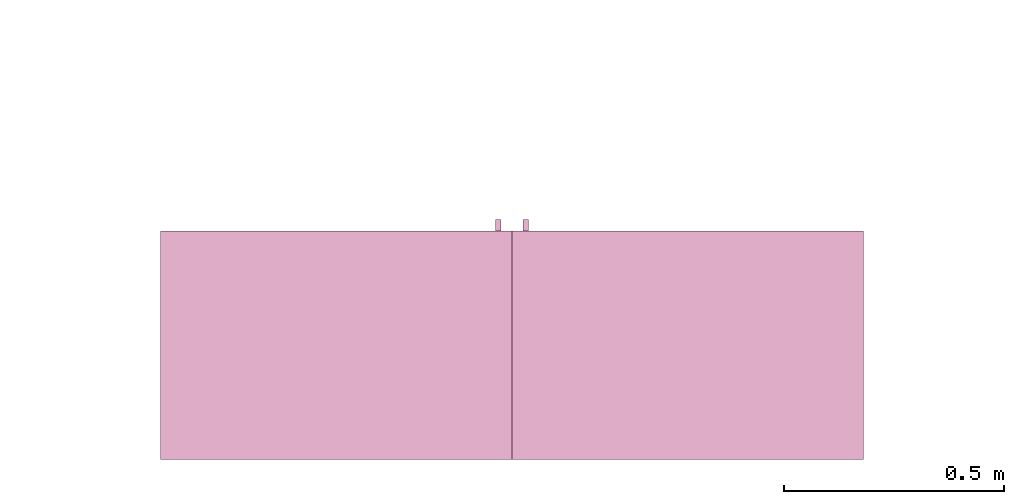
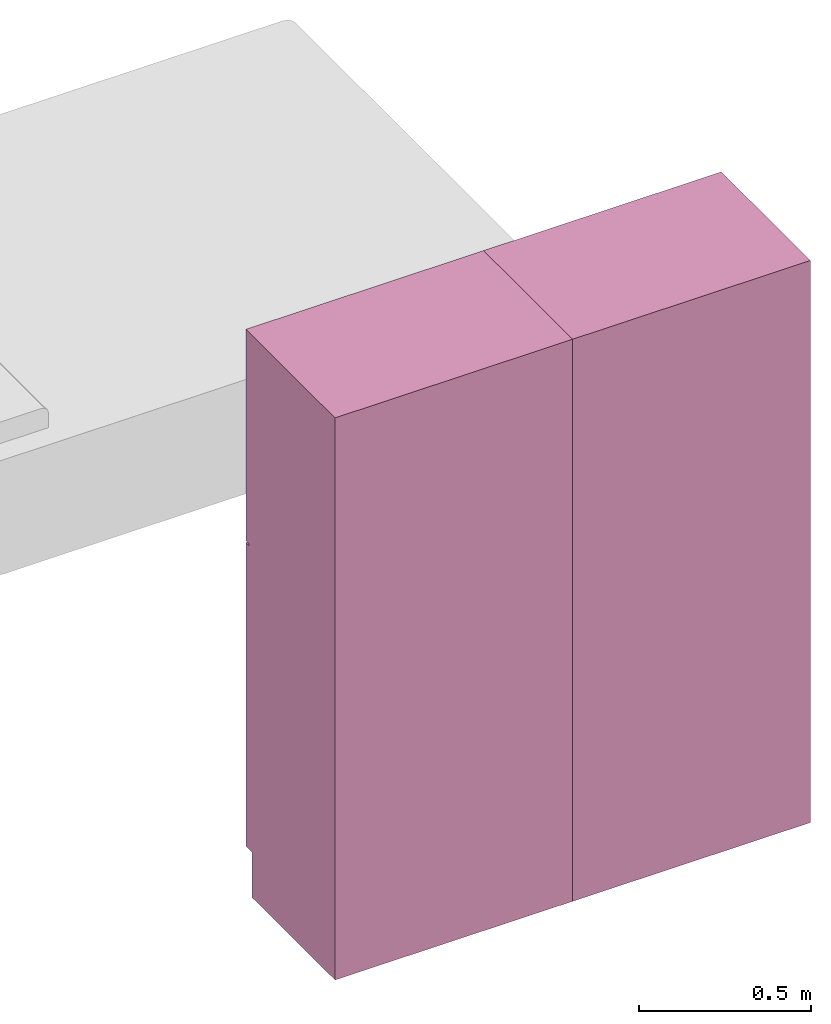
# One storey, part 2 of 3: 2 furnishings, 2 openings.
"""IFC2X3 building model written with IfcOpenShell, lengths in metres."""

from ifc_helpers import new_model, entity, si_unit, converted_unit, frame, origin, origin_with_axes, origin_2d_with_axis, place, context, project, spatial, rectangle, extrude, face_set, surface_model, source, transform, mapped, type_object, type_shapes, element, save


model = new_model("IFC2X3")

# Units and contexts
model_context = context("Model", 3, precision=1e-09, world=origin())
plan_context = context("Plan", 3, precision=1e-09, world=origin())
ifc_project = project(units=[si_unit("LENGTHUNIT", "METRE"), si_unit("AREAUNIT", "SQUARE_METRE"), si_unit("VOLUMEUNIT", "CUBIC_METRE"), converted_unit("PLANEANGLEUNIT", "DEGREE", entity("IfcRatioMeasure", 0.0174532925199433), si_unit("PLANEANGLEUNIT", "RADIAN"), dimensions=[0, 0, 0, 0, 0, 0, 0]), si_unit("TIMEUNIT", "SECOND")], contexts=[model_context, plan_context])

# Site, building, storey, space
site_placement = place(None, origin_with_axes())
site = spatial("IfcSite", under=ifc_project, at=site_placement, CompositionType="ELEMENT")
building_placement = place(None, origin_with_axes())
building = spatial("IfcBuilding", under=site, at=building_placement, CompositionType="ELEMENT")
storey_placement = place(None, frame((0.0, 0.0, 3.10000000000038), z_axis=(0.0, 0.0, 1.0), x_axis=(1.0, 0.0, 0.0)))
storey = spatial("IfcBuildingStorey", under=building, at=storey_placement, Name="Level 2", CompositionType="ELEMENT", Elevation=3.10000000000038)
space_placement = place(None, frame((0.0, 0.0, 3.10000000000038), z_axis=(0.0, 0.0, 1.0), x_axis=(1.0, 0.0, 0.0)))
space = spatial("IfcSpace", under=storey, at=space_placement, CompositionType="ELEMENT", InteriorOrExteriorSpace="INTERNAL")

# Furnishing, opening
furniture_type_1 = type_object("IfcFurnitureType", Name="800 mm", AssemblyPlace="NOTDEFINED")
shared_shape_1 = source(origin(), model_context, "Body", "SurfaceModel", [
    surface_model("IfcFaceBasedSurfaceModel", [(0.8, 0.500950000000002, 0.161587499999842), (0.8, 0.500950000000002, 2.0), (0.0, 0.50095, 2.0), (0.0, 0.50095, 0.161587499999842), (0.780949999999997, 0.500950000000002, 1.98094999999995), (0.780949999999997, 0.500950000000002, 0.180637499999843), (0.0190499999999982, 0.50095, 0.180637499999843), (0.0190499999999982, 0.50095, 1.98094999999995), (0.0, 0.0, 2.0), (0.0, 0.0, 0.0), (0.800000000000003, 0.0, 0.0), (0.800000000000001, 0.0, 2.0), (0.780949999999999, 0.0, 1.98094999999995), (0.780949999999999, 0.0, 0.180637499999843), (0.0190499999999998, 0.0, 0.180637499999843), (0.0190499999999998, 0.0, 1.98094999999995), (0.800000000000003, 0.485, 0.0), (0.8, 0.485, 0.161587499999832), (0.0, 0.485, 0.0), (0.0, 0.485, 0.161587499999842), (0.7746, 0.545400000000002, 1.37154803669582), (0.762067768369355, 0.545400000000002, 1.37154803669582), (0.762067768369355, 0.545400000000002, 1.26994803669581), (0.7746, 0.545400000000002, 1.26994803669581), (0.774599999999999, 0.545400000000002, 1.21914803669582), (0.762067768369354, 0.545400000000002, 1.21914803669582), (0.762067768369354, 0.545400000000002, 1.11754803669582), (0.774599999999999, 0.545400000000002, 1.11754803669582), (0.7746, 0.520000000000002, 1.37154803669582), (0.762067768369356, 0.520000000000002, 1.37154803669582), (0.762067768369356, 0.520000000000002, 1.26994803669581), (0.7746, 0.520000000000002, 1.26994803669581), (0.774599999999999, 0.520000000000002, 1.21914803669582), (0.762067768369354, 0.520000000000002, 1.21914803669582), (0.762067768369354, 0.520000000000002, 1.11754803669582), (0.774599999999999, 0.520000000000002, 1.11754803669582), (0.7365, 0.507300000000002, 1.93649999999996), (0.0635000000000013, 0.5073, 1.93649999999996), (0.0635000000000013, 0.5073, 1.30804803669582), (0.7365, 0.507300000000002, 1.30804803669582), (0.736499999999999, 0.507300000000002, 1.18104803669581), (0.0635000000000007, 0.5073, 1.18104803669581), (0.0635000000000007, 0.5073, 0.22508749999984), (0.736499999999999, 0.507300000000002, 0.22508749999984), (0.7365, 0.500950000000002, 1.93649999999996), (0.0635000000000013, 0.50095, 1.93649999999996), (0.0635000000000013, 0.50095, 1.30804803669582), (0.7365, 0.500950000000002, 1.30804803669582), (0.736499999999999, 0.500950000000002, 1.18104803669581), (0.0635000000000007, 0.50095, 1.18104803669581), (0.0635000000000007, 0.50095, 0.22508749999984), (0.736499999999999, 0.500950000000002, 0.22508749999984), (0.8, 0.520000000000002, 2.0), (0.0, 0.52, 2.0), (0.0, 0.52, 1.24772303669581), (0.8, 0.520000000000002, 1.24772303669581), (0.7365, 0.520000000000002, 1.93649999999996), (0.7365, 0.520000000000002, 1.30804803669582), (0.0635000000000012, 0.52, 1.30804803669582), (0.0635000000000012, 0.52, 1.93649999999996), (0.8, 0.520000000000002, 0.161587499999821), (0.8, 0.520000000000002, 1.24137303669581), (0.0, 0.52, 1.24137303669581), (0.0, 0.52, 0.161587499999821), (0.736499999999999, 0.520000000000002, 1.18104803669582), (0.736499999999999, 0.520000000000002, 0.22508749999984), (0.0635000000000007, 0.52, 0.22508749999984), (0.0635000000000007, 0.52, 1.18104803669582), (0.8, 0.500950000000002, 2.0), (0.0, 0.50095, 2.0), (0.0, 0.50095, 1.24772303669581), (0.8, 0.500950000000002, 1.24772303669581), (0.7365, 0.500950000000002, 1.93649999999996), (0.7365, 0.500950000000002, 1.30804803669582), (0.0635000000000013, 0.50095, 1.30804803669582), (0.0635000000000013, 0.50095, 1.93649999999996), (0.8, 0.500950000000002, 0.161587499999821), (0.8, 0.500950000000002, 1.24137303669581), (0.0, 0.50095, 1.24137303669581), (0.0, 0.50095, 0.161587499999821), (0.736499999999999, 0.500950000000002, 1.18104803669582), (0.736499999999999, 0.500950000000002, 0.22508749999984), (0.0635000000000007, 0.50095, 0.22508749999984), (0.0635000000000007, 0.50095, 1.18104803669582), (0.780949999999999, 0.0190500000000013, 1.98094999999995), (0.0190499999999998, 0.0190500000000013, 1.98094999999995), (0.0190499999999998, 0.0190500000000013, 0.180637499999846), (0.780949999999999, 0.0190500000000013, 0.180637499999846), (0.780949999999999, 0.0, 1.98094999999995), (0.0190499999999998, 0.0, 1.98094999999995), (0.0190499999999999, 0.0, 0.180637499999846), (0.780949999999999, 0.0, 0.180637499999846)], [face_set([[[0, 1, 2, 3], [4, 5, 6, 7]], [[8, 9, 10, 11], [12, 13, 14, 15]], [[1, 11, 10, 16, 17, 0]], [[2, 1, 11, 8]], [[3, 2, 8, 9, 18, 19]], [[0, 17, 19, 3]], [[5, 4, 12, 13]], [[6, 5, 13, 14]], [[7, 6, 14, 15]], [[4, 12, 15, 7]], [[10, 9, 18, 16]], [[18, 16, 17, 19]]]), face_set([[[20, 21, 22, 23]], [[24, 25, 26, 27]], [[28, 29, 30, 31]], [[32, 33, 34, 35]], [[21, 20, 28, 29]], [[22, 30, 29, 21]], [[23, 31, 30, 22]], [[20, 23, 31, 28]], [[25, 24, 32, 33]], [[26, 34, 33, 25]], [[27, 35, 34, 26]], [[24, 27, 35, 32]]]), face_set([[[36, 37, 38, 39]], [[40, 41, 42, 43]], [[44, 45, 46, 47]], [[48, 49, 50, 51]], [[37, 36, 44, 45]], [[38, 37, 45, 46]], [[39, 47, 46, 38]], [[36, 44, 47, 39]], [[41, 40, 48, 49]], [[42, 41, 49, 50]], [[43, 51, 50, 42]], [[40, 48, 51, 43]]]), face_set([[[52, 53, 54, 55], [56, 57, 58, 59]], [[60, 61, 62, 63], [64, 65, 66, 67]], [[68, 69, 70, 71], [72, 73, 74, 75]], [[76, 77, 78, 79], [80, 81, 82, 83]], [[53, 52, 68, 69]], [[54, 70, 69, 53]], [[55, 71, 70, 54]], [[52, 68, 71, 55]], [[61, 77, 76, 60]], [[62, 61, 77, 78]], [[63, 79, 78, 62]], [[60, 76, 79, 63]], [[57, 56, 72, 73]], [[58, 57, 73, 74]], [[59, 75, 74, 58]], [[56, 72, 75, 59]], [[65, 64, 80, 81]], [[66, 65, 81, 82]], [[67, 83, 82, 66]], [[64, 80, 83, 67]]]), face_set([[[84, 85, 86, 87]], [[88, 89, 90, 91]], [[85, 84, 88, 89]], [[86, 90, 89, 85]], [[87, 91, 90, 86]], [[84, 88, 91, 87]]])]),
])
type_shapes(furniture_type_1, [shared_shape_1])
furnishing_1_placement = place(None, frame((2.51699999999999, -6.66599999999999, 3.10000000000038), z_axis=(0.0, 0.0, 1.0), x_axis=(1.0, 0.0, 0.0)))
furnishing_1 = element("IfcFurnishingElement", 1, at=furnishing_1_placement, inside=space, type_object=furniture_type_1, context=model_context, shape_type="MappedRepresentation", body=[
    mapped(shared_shape_1, transform((0.0, 0.0, 0.0), scale=1.0)),
])
placement_1 = place(None, origin())
placement_2 = place(placement_1, origin())
placement_3 = place(placement_2, frame((0.0, 0.0, 3.10000000000038)))
placement_4 = place(placement_3, origin())
opening_1_placement = place(placement_4, frame((2.51699999999999, -6.66599999999999, 0.0)))
element("IfcOpeningElement", 2, at=opening_1_placement, cuts=furnishing_1, ObjectType="Opening", context=model_context, shape_type="SweptSolid", body=[
    extrude(rectangle(XDim=1.80031250000011, YDim=0.761899999999999, at=origin_2d_with_axis()), frame((0.0187377049180251, 0.0, -2.01920625000048), z_axis=(0.0, 1.0, 0.0), x_axis=(0.0, 0.0, -1.0)), (0.0, 0.0, 1.0), 0.50095),
])

furniture_type_2 = type_object("IfcFurnitureType", Name="800 mm", AssemblyPlace="NOTDEFINED")
shared_shape_2 = source(origin(), model_context, "Body", "SurfaceModel", [
    surface_model("IfcFaceBasedSurfaceModel", [(0.8, 0.0444499999999999, 0.161587499999842), (0.0, 0.0444500000000025, 0.161587499999842), (0.0, 0.0444500000000025, 2.0), (0.8, 0.0444499999999999, 2.0), (0.780949999999997, 0.04445, 1.98094999999995), (0.0190499999999982, 0.0444500000000025, 1.98094999999995), (0.0190499999999982, 0.0444500000000025, 0.180637499999843), (0.780949999999997, 0.04445, 0.180637499999843), (0.0, 0.545400000000002, 2.0), (0.800000000000001, 0.5454, 2.0), (0.800000000000003, 0.5454, 0.0), (0.0, 0.545400000000001, 0.0), (0.780949999999999, 0.5454, 1.98094999999995), (0.0190499999999998, 0.545400000000002, 1.98094999999995), (0.0190499999999998, 0.545400000000002, 0.180637499999843), (0.780949999999999, 0.5454, 0.180637499999843), (0.8, 0.0604000000000018, 0.161587499999842), (0.8, 0.0604000000000018, 0.0), (0.0, 0.0604000000000018, 0.0), (0.0, 0.0604000000000018, 0.161587499999832), (0.7746, 0.0, 1.37154803669582), (0.7746, 0.0, 1.26994803669581), (0.762067768369355, 0.0, 1.26994803669581), (0.762067768369355, 0.0, 1.37154803669582), (0.774599999999999, 0.0, 1.21914803669582), (0.774599999999999, 0.0, 1.11754803669582), (0.762067768369354, 0.0, 1.11754803669582), (0.762067768369354, 0.0, 1.21914803669582), (0.7746, 0.0254, 1.37154803669582), (0.7746, 0.0254, 1.26994803669581), (0.762067768369356, 0.0254000000000001, 1.26994803669581), (0.762067768369356, 0.0254000000000001, 1.37154803669582), (0.774599999999999, 0.0254, 1.21914803669582), (0.774599999999999, 0.0254, 1.11754803669582), (0.762067768369354, 0.0254000000000001, 1.11754803669582), (0.762067768369354, 0.0254000000000001, 1.21914803669582), (0.7365, 0.0381000000000001, 1.93649999999996), (0.7365, 0.0381000000000001, 1.30804803669582), (0.0635000000000013, 0.0381000000000023, 1.30804803669582), (0.0635000000000013, 0.0381000000000023, 1.93649999999996), (0.736499999999999, 0.0381000000000001, 1.18104803669581), (0.736499999999999, 0.0381000000000001, 0.22508749999984), (0.0635000000000007, 0.0381000000000023, 0.22508749999984), (0.0635000000000007, 0.0381000000000023, 1.18104803669581), (0.7365, 0.0444500000000001, 1.93649999999996), (0.7365, 0.0444500000000001, 1.30804803669582), (0.0635000000000013, 0.0444500000000023, 1.30804803669582), (0.0635000000000013, 0.0444500000000023, 1.93649999999996), (0.736499999999999, 0.0444500000000001, 1.18104803669581), (0.736499999999999, 0.0444500000000001, 0.22508749999984), (0.0635000000000007, 0.0444500000000023, 0.22508749999984), (0.0635000000000007, 0.0444500000000023, 1.18104803669581), (0.8, 0.0253999999999998, 2.0), (0.8, 0.0253999999999998, 1.24772303669581), (0.0, 0.0254000000000025, 1.24772303669581), (0.0, 0.0254000000000025, 2.0), (0.7365, 0.0254000000000001, 1.93649999999996), (0.0635000000000012, 0.0254000000000023, 1.93649999999996), (0.0635000000000012, 0.0254000000000023, 1.30804803669582), (0.7365, 0.0254000000000001, 1.30804803669582), (0.8, 0.0253999999999998, 0.161587499999821), (0.0, 0.0254000000000025, 0.161587499999821), (0.0, 0.0254000000000025, 1.24137303669581), (0.8, 0.0253999999999998, 1.24137303669581), (0.736499999999999, 0.0254000000000001, 1.18104803669582), (0.0635000000000007, 0.0254000000000023, 1.18104803669582), (0.0635000000000007, 0.0254000000000023, 0.22508749999984), (0.736499999999999, 0.0254000000000001, 0.22508749999984), (0.8, 0.0444499999999998, 2.0), (0.8, 0.0444499999999998, 1.24772303669581), (0.0, 0.0444500000000025, 1.24772303669581), (0.0, 0.0444500000000025, 2.0), (0.7365, 0.0444500000000001, 1.93649999999996), (0.0635000000000013, 0.0444500000000023, 1.93649999999996), (0.0635000000000013, 0.0444500000000023, 1.30804803669582), (0.7365, 0.0444500000000001, 1.30804803669582), (0.8, 0.0444499999999998, 0.161587499999821), (0.0, 0.0444500000000025, 0.161587499999821), (0.0, 0.0444500000000025, 1.24137303669581), (0.8, 0.0444499999999998, 1.24137303669581), (0.736499999999999, 0.0444500000000001, 1.18104803669582), (0.0635000000000007, 0.0444500000000023, 1.18104803669582), (0.0635000000000007, 0.0444500000000023, 0.22508749999984), (0.736499999999999, 0.0444500000000001, 0.22508749999984), (0.780949999999999, 0.526350000000001, 1.98094999999995), (0.780949999999999, 0.526350000000001, 0.180637499999846), (0.0190499999999999, 0.526350000000001, 0.180637499999846), (0.0190499999999998, 0.526350000000001, 1.98094999999995), (0.780949999999999, 0.545400000000001, 1.98094999999995), (0.780949999999999, 0.545400000000001, 0.180637499999846), (0.0190499999999998, 0.545400000000001, 0.180637499999846), (0.0190499999999998, 0.545400000000001, 1.98094999999995)], [face_set([[[0, 1, 2, 3], [4, 5, 6, 7]], [[8, 9, 10, 11], [12, 13, 14, 15]], [[3, 0, 16, 17, 10, 9]], [[2, 8, 9, 3]], [[1, 2, 8, 11, 18, 19]], [[0, 1, 19, 16]], [[7, 15, 12, 4]], [[6, 14, 15, 7]], [[5, 13, 14, 6]], [[4, 5, 13, 12]], [[10, 17, 18, 11]], [[18, 19, 16, 17]]]), face_set([[[20, 21, 22, 23]], [[24, 25, 26, 27]], [[28, 29, 30, 31]], [[32, 33, 34, 35]], [[23, 31, 28, 20]], [[22, 23, 31, 30]], [[21, 22, 30, 29]], [[20, 28, 29, 21]], [[27, 35, 32, 24]], [[26, 27, 35, 34]], [[25, 26, 34, 33]], [[24, 32, 33, 25]]]), face_set([[[36, 37, 38, 39]], [[40, 41, 42, 43]], [[44, 45, 46, 47]], [[48, 49, 50, 51]], [[39, 47, 44, 36]], [[38, 46, 47, 39]], [[37, 38, 46, 45]], [[36, 37, 45, 44]], [[43, 51, 48, 40]], [[42, 50, 51, 43]], [[41, 42, 50, 49]], [[40, 41, 49, 48]]]), face_set([[[52, 53, 54, 55], [56, 57, 58, 59]], [[60, 61, 62, 63], [64, 65, 66, 67]], [[68, 69, 70, 71], [72, 73, 74, 75]], [[76, 77, 78, 79], [80, 81, 82, 83]], [[55, 71, 68, 52]], [[54, 55, 71, 70]], [[53, 54, 70, 69]], [[52, 53, 69, 68]], [[63, 60, 76, 79]], [[62, 78, 79, 63]], [[61, 62, 78, 77]], [[60, 61, 77, 76]], [[59, 75, 72, 56]], [[58, 74, 75, 59]], [[57, 58, 74, 73]], [[56, 57, 73, 72]], [[67, 83, 80, 64]], [[66, 82, 83, 67]], [[65, 66, 82, 81]], [[64, 65, 81, 80]]]), face_set([[[84, 85, 86, 87]], [[88, 89, 90, 91]], [[87, 91, 88, 84]], [[86, 87, 91, 90]], [[85, 86, 90, 89]], [[84, 85, 89, 88]]])]),
])
type_shapes(furniture_type_2, [shared_shape_2])
furnishing_2_placement = place(None, frame((4.11699999999999, -6.1206, 3.10000000000038), z_axis=(0.0, 0.0, 1.0), x_axis=(-1.0, 0.0, 0.0)))
furnishing_2 = element("IfcFurnishingElement", 3, at=furnishing_2_placement, inside=space, type_object=furniture_type_2, context=model_context, shape_type="MappedRepresentation", body=[
    mapped(shared_shape_2, transform((0.0, 0.0, 0.0), scale=1.0)),
])
opening_2_placement = place(placement_4, frame((4.11699999999999, -6.1206, 0.0), z_axis=(0.0, 0.0, 1.0), x_axis=(-1.0, 0.0, 0.0)))
element("IfcOpeningElement", 4, at=opening_2_placement, cuts=furnishing_2, ObjectType="Opening", context=model_context, shape_type="SweptSolid", body=[
    extrude(rectangle(XDim=1.80031250000011, YDim=0.761899999999999, at=origin_2d_with_axis()), frame((-0.0187377049180267, 0.50095, -2.01920625000048), z_axis=(0.0, -1.0, 0.0), x_axis=(0.0, 0.0, -1.0)), (0.0, 0.0, 1.0), 0.50095),
])

save(model, "model.ifc")
